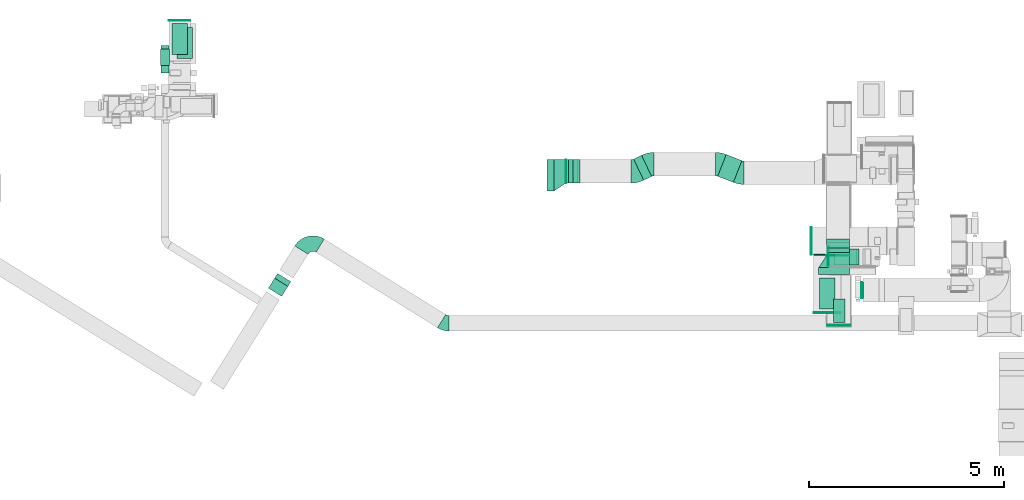
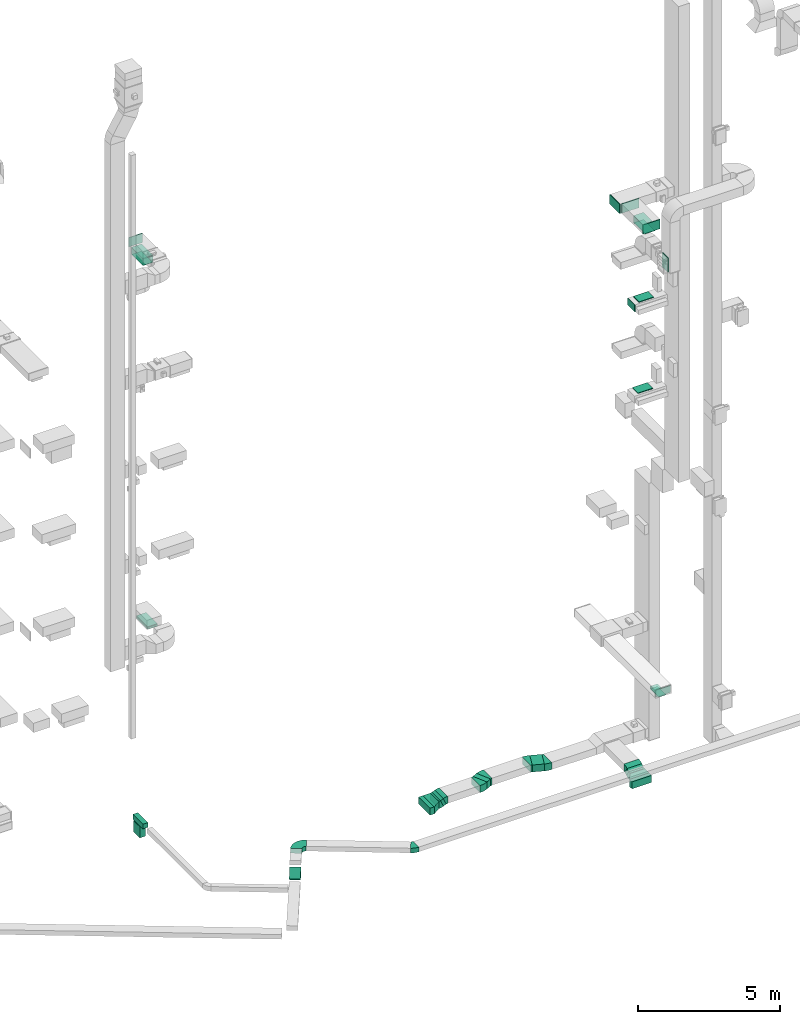
# One storey, part 11 of 25: 23 flow fittings, 18 flow segments, 3 flow terminals.
"""IFC2X3 building model written with IfcOpenShell, lengths in millimetres."""

from ifc_helpers import new_model, entity, si_unit, converted_unit, derived_unit, direction, frame, frame_2d, origin, origin_2d_with_axis, place, context, subcontext, project, spatial, polyline, circle_curve, parameter, trimmed, segment, composite_curve, rectangle, outline, extrude, source, transform, mapped, material, type_object, type_shapes, element, save


model = new_model("IFC2X3")

# Units and contexts
model_context = context("Model", 3, precision=0.01, world=origin(), true_north=direction((6.12303176911189e-17, 1.0)))
body_context = subcontext(model_context, "Body", "Model", "MODEL_VIEW")
ifc_project = project(units=[si_unit("LENGTHUNIT", "METRE", prefix="MILLI"), si_unit("AREAUNIT", "SQUARE_METRE"), si_unit("VOLUMEUNIT", "CUBIC_METRE"), converted_unit("PLANEANGLEUNIT", "DEGREE", entity("IfcRatioMeasure", 0.0174532925199433), si_unit("PLANEANGLEUNIT", "RADIAN"), dimensions=[0, 0, 0, 0, 0, 0, 0]), si_unit("MASSUNIT", "GRAM", prefix="KILO"), derived_unit("MASSDENSITYUNIT", [(si_unit("MASSUNIT", "GRAM", prefix="KILO"), 1), (si_unit("LENGTHUNIT", "METRE"), -3)]), derived_unit("MOMENTOFINERTIAUNIT", [(si_unit("LENGTHUNIT", "METRE"), 4)]), si_unit("TIMEUNIT", "SECOND"), si_unit("FREQUENCYUNIT", "HERTZ"), si_unit("THERMODYNAMICTEMPERATUREUNIT", "DEGREE_CELSIUS"), derived_unit("THERMALTRANSMITTANCEUNIT", [(si_unit("MASSUNIT", "GRAM", prefix="KILO"), 1), (si_unit("THERMODYNAMICTEMPERATUREUNIT", "KELVIN"), -1), (si_unit("TIMEUNIT", "SECOND"), -3)]), derived_unit("VOLUMETRICFLOWRATEUNIT", [(si_unit("LENGTHUNIT", "METRE"), 3), (si_unit("TIMEUNIT", "SECOND"), -1)]), derived_unit("MASSFLOWRATEUNIT", [(si_unit("MASSUNIT", "GRAM", prefix="KILO"), 1), (si_unit("TIMEUNIT", "SECOND"), -1)]), derived_unit("ROTATIONALFREQUENCYUNIT", [(si_unit("TIMEUNIT", "SECOND"), -1)]), si_unit("ELECTRICCURRENTUNIT", "AMPERE"), si_unit("ELECTRICVOLTAGEUNIT", "VOLT"), si_unit("POWERUNIT", "WATT"), si_unit("FORCEUNIT", "NEWTON", prefix="KILO"), si_unit("ILLUMINANCEUNIT", "LUX"), si_unit("LUMINOUSFLUXUNIT", "LUMEN"), si_unit("LUMINOUSINTENSITYUNIT", "CANDELA"), derived_unit("USERDEFINED", [(si_unit("MASSUNIT", "GRAM", prefix="KILO"), -1), (si_unit("LENGTHUNIT", "METRE"), -2), (si_unit("TIMEUNIT", "SECOND"), 3), (si_unit("LUMINOUSFLUXUNIT", "LUMEN"), 1)]), derived_unit("LINEARVELOCITYUNIT", [(si_unit("LENGTHUNIT", "METRE"), 1), (si_unit("TIMEUNIT", "SECOND"), -1)]), si_unit("PRESSUREUNIT", "PASCAL"), derived_unit("USERDEFINED", [(si_unit("LENGTHUNIT", "METRE"), -2), (si_unit("MASSUNIT", "GRAM", prefix="KILO"), 1), (si_unit("TIMEUNIT", "SECOND"), -2)]), derived_unit("LINEARFORCEUNIT", [(si_unit("MASSUNIT", "GRAM", prefix="KILO"), 1), (si_unit("LENGTHUNIT", "METRE"), 1), (si_unit("TIMEUNIT", "SECOND"), -2), (si_unit("LENGTHUNIT", "METRE"), -1)]), derived_unit("PLANARFORCEUNIT", [(si_unit("MASSUNIT", "GRAM", prefix="KILO"), 1), (si_unit("LENGTHUNIT", "METRE"), 1), (si_unit("TIMEUNIT", "SECOND"), -2), (si_unit("LENGTHUNIT", "METRE"), -2)])], contexts=[model_context])

# Site, building, storey
site_placement = place(None, origin())
site = spatial("IfcSite", under=ifc_project, at=site_placement, CompositionType="ELEMENT")
building_placement = place(site_placement, origin())
building = spatial("IfcBuilding", under=site, at=building_placement, CompositionType="ELEMENT")
storey_placement = place(building_placement, origin())
storey = spatial("IfcBuildingStorey", under=building, at=storey_placement, CompositionType="ELEMENT", Elevation=0.0)

# Flow segments
duct_segment_type = type_object("IfcDuctSegmentType", PredefinedType="NOTDEFINED")
flow_segment_1_placement = place(storey_placement, frame((28295.0, 9540.32, 22200.0)))
element("IfcFlowSegment", 1, at=flow_segment_1_placement, inside=storey, type_object=duct_segment_type, context=body_context, shape_type="SweptSolid", body=[
    extrude(rectangle(XDim=800.000000000001, YDim=400.0, at=origin_2d_with_axis()), frame((200.0, 400.0, 0.0), z_axis=(0.0, 0.0, 1.0), x_axis=(0.0, 1.0, 0.0)), (0.0, 0.0, 1.0), 280.000004231565),
])
flow_segment_2_placement = place(storey_placement, frame((28651.05, 9196.31, 2400.0)))
element("IfcFlowSegment", 2, at=flow_segment_2_placement, inside=storey, type_object=duct_segment_type, context=body_context, shape_type="SweptSolid", body=[
    extrude(rectangle(XDim=600.0, YDim=300.000000000001, at=origin_2d_with_axis()), frame((150.0, 300.0, 0.0), z_axis=(0.0, 0.0, 1.0), x_axis=(0.0, 1.0, 0.0)), (0.0, 0.0, 1.0), 79.9999999999699),
])
flow_segment_3_placement = place(storey_placement, frame((11808.22, 15969.97, 7100.0)))
element("IfcFlowSegment", 3, at=flow_segment_3_placement, inside=storey, type_object=duct_segment_type, context=body_context, shape_type="SweptSolid", body=[
    extrude(rectangle(XDim=800.0, YDim=400.0, at=origin_2d_with_axis()), frame((200.0, 400.0, 0.0), z_axis=(0.0, 0.0, 1.0), x_axis=(0.0, 1.0, 0.0)), (0.0, 0.0, 1.0), 79.9999999999991),
])
flow_segment_4_placement = place(storey_placement, frame((11399.83, 15599.98, -1100.0)))
element("IfcFlowSegment", 4, at=flow_segment_4_placement, inside=storey, type_object=duct_segment_type, context=body_context, shape_type="SweptSolid", body=[
    extrude(rectangle(XDim=705.699024463295, YDim=200.0, at=origin_2d_with_axis()), frame((100.0, 352.85, 0.0), z_axis=(0.0, 0.0, 1.0), x_axis=(0.0, 1.0, 0.0)), (0.0, 0.0, 1.0), 200.0),
])
flow_segment_5_placement = place(storey_placement, frame((11387.33, 15795.43, -1600.0)))
element("IfcFlowSegment", 5, at=flow_segment_5_placement, inside=storey, type_object=duct_segment_type, context=body_context, shape_type="SweptSolid", body=[
    extrude(rectangle(XDim=225.000000000001, YDim=425.000000000001, at=origin_2d_with_axis()), frame((112.5, 212.5, 0.0), z_axis=(0.0, 0.0, 1.0), x_axis=(-1.0, 0.0, 0.0)), (0.0, 0.0, 1.0), 479.999999999649),
])
flow_segment_6_placement = place(storey_placement, frame((28661.92, 10677.38, 14520.0)))
element("IfcFlowSegment", 6, at=flow_segment_6_placement, inside=storey, type_object=duct_segment_type, context=body_context, shape_type="SweptSolid", body=[
    extrude(rectangle(XDim=400.000000000002, YDim=600.000000000002, at=origin_2d_with_axis()), frame((300.0, 200.0, 0.0), z_axis=(0.0, 0.0, 1.0), x_axis=(0.0, 1.0, 0.0)), (0.0, 0.0, 1.0), 30.0000000000387),
])
flow_segment_7_placement = place(storey_placement, frame((14154.27, 9867.26, -997.49)))
element("IfcFlowSegment", 7, at=flow_segment_7_placement, inside=storey, type_object=duct_segment_type, context=body_context, shape_type="SweptSolid", body=[
    extrude(rectangle(XDim=199.999999999998, YDim=400.0, at=origin_2d_with_axis()), frame((207.08, 165.95, 70.71), z_axis=(0.374709505220615, 0.599660559564594, 0.707106781186548), x_axis=(-0.374709505220592, -0.599660559564608, 0.707106781186548)), (0.0, 0.0, 1.0), 429.289321881347),
])
flow_segment_8_placement = place(storey_placement, frame((28706.92, 10677.38, 18420.0)))
element("IfcFlowSegment", 8, at=flow_segment_8_placement, inside=storey, type_object=duct_segment_type, context=body_context, shape_type="SweptSolid", body=[
    extrude(rectangle(XDim=400.0, YDim=600.000000000002, at=origin_2d_with_axis()), frame((300.0, 200.0, 0.0), z_axis=(0.0, 0.0, 1.0), x_axis=(0.0, 1.0, 0.0)), (0.0, 0.0, 1.0), 30.0000000000148),
])
flow_segment_9_placement = place(storey_placement, frame((29370.56, 9824.93, 20000.0)))
element("IfcFlowSegment", 9, at=flow_segment_9_placement, inside=storey, type_object=duct_segment_type, context=body_context, shape_type="SweptSolid", body=[
    extrude(rectangle(XDim=24.9999999998774, YDim=400.0, at=origin_2d_with_axis()), frame((12.5, 200.0, 0.0), z_axis=(0.0, 0.0, 1.0), x_axis=(-1.0, 0.0, 0.0)), (0.0, 0.0, 1.0), 600.000000000002),
])
flow_segment_10_placement = place(storey_placement, frame((11675.64, 16071.13, 22700.0)))
element("IfcFlowSegment", 10, at=flow_segment_10_placement, inside=storey, type_object=duct_segment_type, context=body_context, shape_type="SweptSolid", body=[
    extrude(rectangle(XDim=400.0, YDim=800.0, at=origin_2d_with_axis()), frame((200.0, 400.0, 0.0)), (0.0, 0.0, 1.0), 280.00000000001),
])
flow_segment_11_placement = place(storey_placement, frame((21308.44, 12574.72, -2150.0)))
element("IfcFlowSegment", 11, at=flow_segment_11_placement, inside=storey, type_object=duct_segment_type, context=body_context, shape_type="SweptSolid", body=[
    extrude(rectangle(XDim=180.000000000167, YDim=800.0, at=origin_2d_with_axis()), frame((90.0, 400.0, 0.0)), (0.0, 0.0, 1.0), 300.0),
])
flow_segment_12_placement = place(storey_placement, frame((25682.11, 12791.58, -2050.0)))
element("IfcFlowSegment", 12, at=flow_segment_12_placement, inside=storey, type_object=duct_segment_type, context=body_context, shape_type="SweptSolid", body=[
    extrude(rectangle(XDim=431.766619119169, YDim=600.000000000001, at=origin_2d_with_axis()), frame((310.57, 358.14, 0.0), z_axis=(0.0, 0.0, 1.0), x_axis=(-0.930851591492938, 0.365397474834002, 0.0)), (0.0, 0.0, 1.0), 300.0),
])
flow_segment_13_placement = place(storey_placement, frame((23525.08, 12847.78, -2050.0)))
element("IfcFlowSegment", 13, at=flow_segment_13_placement, inside=storey, type_object=duct_segment_type, context=body_context, shape_type="SweptSolid", body=[
    extrude(rectangle(XDim=226.103922493207, YDim=600.0, at=origin_2d_with_axis()), frame((231.19, 319.45, 0.0), z_axis=(0.0, 0.0, 1.0), x_axis=(0.902595103311304, 0.430490510323348, 0.0)), (0.0, 0.0, 1.0), 300.0),
])
flow_segment_14_placement = place(storey_placement, frame((28269.95, 10425.0, -2150.0)))
element("IfcFlowSegment", 14, at=flow_segment_14_placement, inside=storey, type_object=duct_segment_type, context=body_context, shape_type="SweptSolid", body=[
    extrude(rectangle(XDim=180.000000000057, YDim=800.0, at=origin_2d_with_axis()), frame((400.0, 90.0, 0.0), z_axis=(0.0, 0.0, 1.0), x_axis=(0.0, -1.0, 0.0)), (0.0, 0.0, 1.0), 300.0),
])
flow_segment_15_placement = place(storey_placement, frame((28469.95, 10905.0, -2150.0)))
element("IfcFlowSegment", 15, at=flow_segment_15_placement, inside=storey, type_object=duct_segment_type, context=body_context, shape_type="SweptSolid", body=[
    extrude(rectangle(XDim=11.7313523662842, YDim=600.000000000002, at=origin_2d_with_axis()), frame((300.0, 5.87, 0.0), z_axis=(0.0, 0.0, 1.0), x_axis=(0.0, 1.0, 0.0)), (0.0, 0.0, 1.0), 300.0),
])
flow_segment_16_placement = place(storey_placement, frame((28469.95, 10991.73, -2089.71)))
element("IfcFlowSegment", 16, at=flow_segment_16_placement, inside=storey, type_object=duct_segment_type, context=body_context, shape_type="SweptSolid", body=[
    extrude(rectangle(XDim=299.999999999998, YDim=139.230496196381, at=frame_2d((0.0, 0.0), x_axis=(0.0, 1.0))), frame((0.0, 135.29, 164.71), z_axis=(1.0, 0.0, 0.0), x_axis=(0.0, 0.866025410712421, 0.499999988000383)), (0.0, 0.0, 1.0), 599.999999999998),
])
flow_segment_17_placement = place(storey_placement, frame((21788.44, 12774.72, -2150.0)))
element("IfcFlowSegment", 17, at=flow_segment_17_placement, inside=storey, type_object=duct_segment_type, context=body_context, shape_type="SweptSolid", body=[
    extrude(rectangle(XDim=6.88577027826406, YDim=600.0, at=origin_2d_with_axis()), frame((3.44, 300.0, 0.0)), (0.0, 0.0, 1.0), 300.0),
])
flow_segment_18_placement = place(storey_placement, frame((21855.76, 12774.72, -2111.85)))
element("IfcFlowSegment", 18, at=flow_segment_18_placement, inside=storey, type_object=duct_segment_type, context=body_context, shape_type="SweptSolid", body=[
    extrude(rectangle(XDim=300.000000000003, YDim=121.954891093288, at=frame_2d((0.0, 0.0), x_axis=(0.0, 1.0))), frame((116.25, 0.0, 161.85), z_axis=(0.0, 1.0, 0.0), x_axis=(-0.915231716678703, 0.0, -0.402927915122984)), (0.0, 0.0, 1.0), 600.000000000002),
])

# Flow fittings
ifc_material_1 = material()
duct_fitting_type_1 = type_object("IfcDuctFittingType", PredefinedType="NOTDEFINED", material=ifc_material_1)
shared_shape_1 = source(origin(), body_context, "Body", "SweptSolid", [
    extrude(rectangle(XDim=24.9999999999999, YDim=700.0, at=origin_2d_with_axis()), frame((12.5, 0.0, -200.0)), (0.0, 0.0, 1.0), 400.0),
])
type_shapes(duct_fitting_type_1, [shared_shape_1])
for number, where, z_axis, x_axis in (
    (19, (28495.0, 9460.01, 22500.0), (0.0, 0.0, 1.0), (0.0, -1.0, 0.0)),
    (20, (28095.0, 11289.62, 22500.0), (0.0, 0.0, 1.0), (-1.0, 0.0, 0.0)),
):
    element("IfcFlowFitting", number, at=place(storey_placement, frame(where, z_axis=z_axis, x_axis=x_axis)), inside=storey, type_object=duct_fitting_type_1, material=ifc_material_1, context=body_context, shape_type="MappedRepresentation", body=[
        mapped(shared_shape_1, transform((0.0, 0.0, 0.0), scale=1.0)),
    ])

# Flow terminal
ifc_material_2 = material()
air_terminal_type_1 = type_object("IfcAirTerminalType", PredefinedType="NOTDEFINED", material=ifc_material_2)
shared_shape_2 = source(origin(), body_context, "Body", "SweptSolid", [
    extrude(rectangle(XDim=4.0, YDim=799.999999999999, at=origin_2d_with_axis()), frame((0.0, -2.0, -200.0), z_axis=(0.0, 0.0, 1.0), x_axis=(0.0, 1.0, 0.0)), (0.0, 0.0, 1.0), 400.000000000005),
])
type_shapes(air_terminal_type_1, [shared_shape_2])
flow_terminal_1_placement = place(storey_placement, frame((28495.0, 9940.32, 22200.0), z_axis=(-1.0, 0.0, 0.0), x_axis=(0.0, -1.0, 0.0)))
element("IfcFlowTerminal", 21, at=flow_terminal_1_placement, inside=storey, type_object=air_terminal_type_1, material=ifc_material_2, context=body_context, shape_type="MappedRepresentation", body=[
    mapped(shared_shape_2, transform((0.0, 0.0, 0.0), scale=1.0)),
])

# Flow fittings
duct_fitting_type_2 = type_object("IfcDuctFittingType", PredefinedType="NOTDEFINED", material=ifc_material_1)
shared_shape_3 = source(origin(), body_context, "Body", "SweptSolid", [
    extrude(rectangle(XDim=26.0960000000012, YDim=800.0, at=origin_2d_with_axis()), frame((6.95, 0.0, -200.0)), (0.0, 0.0, 1.0), 400.0),
])
type_shapes(duct_fitting_type_2, [shared_shape_3])
flow_fitting_1_placement = place(storey_placement, frame((11875.64, 16471.13, 23000.0), z_axis=(1.0, 0.0, 0.0), x_axis=(0.0, 0.0, -1.0)))
element("IfcFlowFitting", 22, at=flow_fitting_1_placement, inside=storey, type_object=duct_fitting_type_2, material=ifc_material_1, context=body_context, shape_type="MappedRepresentation", body=[
    mapped(shared_shape_3, transform((0.0, 0.0, 0.0), scale=1.0)),
])
duct_fitting_type_3 = type_object("IfcDuctFittingType", PredefinedType="NOTDEFINED", material=ifc_material_1)
shared_shape_4 = source(origin(), body_context, "Body", "SweptSolid", [
    extrude(rectangle(XDim=800.0, YDim=26.096, at=origin_2d_with_axis()), frame((6.95, 0.0, -200.0), z_axis=(0.0, 0.0, 1.0), x_axis=(0.0, -1.0, 0.0)), (0.0, 0.0, 1.0), 400.0),
])
type_shapes(duct_fitting_type_3, [shared_shape_4])
flow_fitting_2_placement = place(storey_placement, frame((28495.0, 9940.32, 22500.0), z_axis=(-1.0, 0.0, 0.0), x_axis=(0.0, 0.0, -1.0)))
element("IfcFlowFitting", 23, at=flow_fitting_2_placement, inside=storey, type_object=duct_fitting_type_3, material=ifc_material_1, context=body_context, shape_type="MappedRepresentation", body=[
    mapped(shared_shape_4, transform((0.0, 0.0, 0.0), scale=1.0)),
])
duct_fitting_type_4 = type_object("IfcDuctFittingType", PredefinedType="NOTDEFINED", material=ifc_material_1)
shared_shape_5 = source(origin(), body_context, "Body", "SweptSolid", [
    extrude(rectangle(XDim=400.0, YDim=26.0960000000022, at=origin_2d_with_axis()), frame((6.95, 0.0, -400.0), z_axis=(0.0, 0.0, 1.0), x_axis=(0.0, -1.0, 0.0)), (0.0, 0.0, 1.0), 800.0),
])
type_shapes(duct_fitting_type_4, [shared_shape_5])
flow_fitting_3_placement = place(storey_placement, frame((12008.22, 16369.97, 7200.0), z_axis=(0.0, 1.0, 0.0), x_axis=(0.0, 0.0, -1.0)))
element("IfcFlowFitting", 24, at=flow_fitting_3_placement, inside=storey, type_object=duct_fitting_type_4, material=ifc_material_1, context=body_context, shape_type="MappedRepresentation", body=[
    mapped(shared_shape_5, transform((0.0, 0.0, 0.0), scale=1.0)),
])
duct_fitting_type_5 = type_object("IfcDuctFittingType", PredefinedType="NOTDEFINED", material=ifc_material_1)
shared_shape_6 = source(origin(), body_context, "Body", "SweptSolid", [
    extrude(rectangle(XDim=24.9999999999999, YDim=600.0, at=origin_2d_with_axis()), frame((12.5, 0.0, -150.0)), (0.0, 0.0, 1.0), 300.0),
])
type_shapes(duct_fitting_type_5, [shared_shape_6])
flow_fitting_4_placement = place(storey_placement, frame((28789.1, 9142.08, 2650.0), z_axis=(0.0, 0.0, 1.0), x_axis=(0.0, -1.0, 0.0)))
element("IfcFlowFitting", 25, at=flow_fitting_4_placement, inside=storey, type_object=duct_fitting_type_5, material=ifc_material_1, context=body_context, shape_type="MappedRepresentation", body=[
    mapped(shared_shape_6, transform((0.0, 0.0, 0.0), scale=1.0)),
])
duct_fitting_type_6 = type_object("IfcDuctFittingType", PredefinedType="NOTDEFINED", material=ifc_material_1)
shared_shape_7 = source(origin(), body_context, "Body", "SweptSolid", [
    extrude(rectangle(XDim=300.0, YDim=26.0960000000498, at=origin_2d_with_axis()), frame((6.95, 0.0, -300.0), z_axis=(0.0, 0.0, 1.0), x_axis=(0.0, -1.0, 0.0)), (0.0, 0.0, 1.0), 600.0),
])
type_shapes(duct_fitting_type_6, [shared_shape_7])
flow_fitting_5_placement = place(storey_placement, frame((28801.05, 9496.31, 2500.0), z_axis=(0.0, 1.0, 0.0), x_axis=(0.0, 0.0, -1.0)))
element("IfcFlowFitting", 26, at=flow_fitting_5_placement, inside=storey, type_object=duct_fitting_type_6, material=ifc_material_1, context=body_context, shape_type="MappedRepresentation", body=[
    mapped(shared_shape_7, transform((0.0, 0.0, 0.0), scale=1.0)),
])

# Flow terminal
air_terminal_type_2 = type_object("IfcAirTerminalType", PredefinedType="NOTDEFINED", material=ifc_material_2)
shared_shape_8 = source(origin(), body_context, "Body", "SweptSolid", [
    extrude(rectangle(XDim=4.0, YDim=599.999999999999, at=origin_2d_with_axis()), frame((0.0, -2.0, -150.0), z_axis=(0.0, 0.0, 1.0), x_axis=(0.0, 1.0, 0.0)), (0.0, 0.0, 1.0), 300.000000000005),
])
type_shapes(air_terminal_type_2, [shared_shape_8])
flow_terminal_2_placement = place(storey_placement, frame((28801.05, 9496.31, 2400.0), z_axis=(-1.0, 0.0, 0.0), x_axis=(0.0, -1.0, 0.0)))
element("IfcFlowTerminal", 27, at=flow_terminal_2_placement, inside=storey, type_object=air_terminal_type_2, material=ifc_material_2, context=body_context, shape_type="MappedRepresentation", body=[
    mapped(shared_shape_8, transform((0.0, 0.0, 0.0), scale=1.0)),
])

# Flow fittings
duct_fitting_type_7 = type_object("IfcDuctFittingType", PredefinedType="NOTDEFINED", material=ifc_material_1)
shared_shape_9 = source(origin(), body_context, "Body", "SweptSolid", [
    extrude(rectangle(XDim=24.9999999999999, YDim=500.0, at=origin_2d_with_axis()), frame((12.5, 0.0, -150.0)), (0.0, 0.0, 1.0), 300.0),
])
type_shapes(duct_fitting_type_7, [shared_shape_9])
flow_fitting_6_placement = place(storey_placement, frame((28533.94, 10897.38, 18250.0), z_axis=(0.0, 0.0, 1.0), x_axis=(-1.0, 0.0, 0.0)))
element("IfcFlowFitting", 28, at=flow_fitting_6_placement, inside=storey, type_object=duct_fitting_type_7, material=ifc_material_1, context=body_context, shape_type="MappedRepresentation", body=[
    mapped(shared_shape_9, transform((0.0, 0.0, 0.0), scale=1.0)),
])
duct_fitting_type_8 = type_object("IfcDuctFittingType", PredefinedType="NOTDEFINED", material=ifc_material_1)
shared_shape_10 = source(origin(), body_context, "Body", "SweptSolid", [
    extrude(rectangle(XDim=24.9999999999999, YDim=550.0, at=origin_2d_with_axis()), frame((12.5, 0.0, -200.0)), (0.0, 0.0, 1.0), 400.0),
])
type_shapes(duct_fitting_type_8, [shared_shape_10])
flow_fitting_7_placement = place(storey_placement, frame((11874.64, 16933.77, 23200.0), z_axis=(0.0, 0.0, 1.0), x_axis=(0.0, 1.0, 0.0)))
element("IfcFlowFitting", 29, at=flow_fitting_7_placement, inside=storey, type_object=duct_fitting_type_8, material=ifc_material_1, context=body_context, shape_type="MappedRepresentation", body=[
    mapped(shared_shape_10, transform((0.0, 0.0, 0.0), scale=1.0)),
])
duct_fitting_type_9 = type_object("IfcDuctFittingType", PredefinedType="NOTDEFINED", material=ifc_material_1)
shared_shape_11 = source(origin(), body_context, "Body", "SweptSolid", [
    extrude(rectangle(XDim=600.0, YDim=26.096, at=origin_2d_with_axis()), frame((6.95, 0.0, -200.0), z_axis=(0.0, 0.0, 1.0), x_axis=(0.0, -1.0, 0.0)), (0.0, 0.0, 1.0), 400.0),
])
type_shapes(duct_fitting_type_9, [shared_shape_11])
flow_fitting_8_placement = place(storey_placement, frame((29415.56, 10024.93, 20300.0), z_axis=(0.0, 1.0, 0.0), x_axis=(-1.0, 0.0, 0.0)))
element("IfcFlowFitting", 30, at=flow_fitting_8_placement, inside=storey, type_object=duct_fitting_type_9, material=ifc_material_1, context=body_context, shape_type="MappedRepresentation", body=[
    mapped(shared_shape_11, transform((0.0, 0.0, 0.0), scale=1.0)),
])

# Flow terminal
air_terminal_type_3 = type_object("IfcAirTerminalType", PredefinedType="NOTDEFINED", material=ifc_material_2)
shared_shape_12 = source(origin(), body_context, "Body", "SweptSolid", [
    extrude(rectangle(XDim=4.0, YDim=799.999999999999, at=origin_2d_with_axis()), frame((0.0, -2.0, -200.0), z_axis=(0.0, 0.0, 1.0), x_axis=(0.0, 1.0, 0.0)), (0.0, 0.0, 1.0), 400.000000000005),
])
type_shapes(air_terminal_type_3, [shared_shape_12])
flow_terminal_3_placement = place(storey_placement, frame((11875.64, 16470.13, 22700.0), z_axis=(-1.0, 0.0, 0.0), x_axis=(0.0, -1.0, 0.0)))
element("IfcFlowTerminal", 31, at=flow_terminal_3_placement, inside=storey, type_object=air_terminal_type_3, material=ifc_material_2, context=body_context, shape_type="MappedRepresentation", body=[
    mapped(shared_shape_12, transform((0.0, 0.0, 0.0), scale=1.0)),
])

# Flow fittings
duct_fitting_type_10 = type_object("IfcDuctFittingType", PredefinedType="NOTDEFINED", material=ifc_material_1)
shared_shape_13 = source(origin(), body_context, "Body", "SweptSolid", [
    extrude(rectangle(XDim=700.0, YDim=26.096, at=origin_2d_with_axis()), frame((6.95, 0.0, -200.0), z_axis=(0.0, 0.0, 1.0), x_axis=(0.0, -1.0, 0.0)), (0.0, 0.0, 1.0), 400.0),
])
type_shapes(duct_fitting_type_10, [shared_shape_13])
flow_fitting_9_placement = place(storey_placement, frame((28495.0, 10939.62, 22500.0), z_axis=(0.0, 0.0, -1.0), x_axis=(0.0, -1.0, 0.0)))
element("IfcFlowFitting", 32, at=flow_fitting_9_placement, inside=storey, type_object=duct_fitting_type_10, material=ifc_material_1, context=body_context, shape_type="MappedRepresentation", body=[
    mapped(shared_shape_13, transform((0.0, 0.0, 0.0), scale=1.0)),
])
duct_fitting_type_11 = type_object("IfcDuctFittingType", PredefinedType="NOTDEFINED", material=ifc_material_1)
shared_shape_14 = source(origin(), body_context, "Body", "SweptSolid", [
    extrude(outline(polyline([(-374.42, -291.22), (-13.87, -291.22), (318.95, 208.01), (69.34, 374.42), (-374.42, -291.22)])), frame((150.0, 50.0, -150.0), z_axis=(0.0, 0.0, 1.0), x_axis=(0.832050294337843, 0.55470019622523, 0.0)), (0.0, 0.0, 1.0), 300.0),
])
type_shapes(duct_fitting_type_11, [shared_shape_14])
flow_fitting_10_placement = place(storey_placement, frame((21488.44, 12974.72, -2000.0)))
element("IfcFlowFitting", 33, at=flow_fitting_10_placement, inside=storey, type_object=duct_fitting_type_11, material=ifc_material_1, context=body_context, shape_type="MappedRepresentation", body=[
    mapped(shared_shape_14, transform((0.0, 0.0, 0.0), scale=1.0)),
])
duct_fitting_type_12 = type_object("IfcDuctFittingType", PredefinedType="NOTDEFINED", material=ifc_material_1)
shared_shape_15 = source(origin(), body_context, "Body", "SweptSolid", [
    extrude(outline(polyline([(-150.0, -350.0), (150.0, -350.0), (150.0, 250.0), (-150.0, 450.0), (-150.0, -350.0)])), frame((150.0, -50.0, -150.0)), (0.0, 0.0, 1.0), 300.0),
])
type_shapes(duct_fitting_type_12, [shared_shape_15])
flow_fitting_11_placement = place(storey_placement, frame((28669.95, 10605.0, -2000.0), z_axis=(0.0, 0.0, 1.0), x_axis=(0.0, 1.0, 0.0)))
element("IfcFlowFitting", 34, at=flow_fitting_11_placement, inside=storey, type_object=duct_fitting_type_12, material=ifc_material_1, context=body_context, shape_type="MappedRepresentation", body=[
    mapped(shared_shape_15, transform((0.0, 0.0, 0.0), scale=1.0)),
])
duct_fitting_type_13 = type_object("IfcDuctFittingType", PredefinedType="NOTDEFINED", material=ifc_material_1)
shared_shape_16 = source(origin(), body_context, "Body", "SweptSolid", [
    extrude(outline(composite_curve([segment(polyline([(-315.56, -82.21), (284.44, -82.21)]), True, "CONTINUOUS"), segment(trimmed(circle_curve(frame_2d((434.44, -82.21), x_axis=(-0.930851591492948, 0.365397474833975)), 150.0), [parameter(0.0)], [parameter(21.4320460265405)], True, "PARAMETER"), False, "CONTINUOUS"), segment(polyline([(294.81, -27.4), (-263.7, 191.83)]), True, "CONTINUOUS"), segment(trimmed(circle_curve(frame_2d((434.44, -82.21), x_axis=(-0.930851591492948, 0.365397474833975)), 750.0), [parameter(0.0)], [parameter(21.4320460265405)], True, "PARAMETER"), True, "CONTINUOUS")], self_intersect=False)), frame((-2.94, 15.56, -150.0), z_axis=(0.0, 0.0, 1.0), x_axis=(-0.365397474833975, 0.930851591492948, 0.0)), (0.0, 0.0, 1.0), 300.0),
])
type_shapes(duct_fitting_type_13, [shared_shape_16])
for number, where, z_axis, x_axis in (
    (35, (25712.46, 13259.72, -1900.0), (0.0, 0.0, 1.0), (-0.930851591492938, 0.365397474834001, 0.0)),
    (36, (26272.91, 13039.72, -1900.0), (0.0, 0.0, 1.0), (0.930851591492938, -0.365397474834, 0.0)),
):
    element("IfcFlowFitting", number, at=place(storey_placement, frame(where, z_axis=z_axis, x_axis=x_axis)), inside=storey, type_object=duct_fitting_type_13, material=ifc_material_1, context=body_context, shape_type="MappedRepresentation", body=[
        mapped(shared_shape_16, transform((0.0, 0.0, 0.0), scale=1.0)),
    ])
duct_fitting_type_14 = type_object("IfcDuctFittingType", PredefinedType="NOTDEFINED", material=ifc_material_1)
shared_shape_17 = source(origin(), body_context, "Body", "SweptSolid", [
    extrude(outline(composite_curve([segment(polyline([(-321.92, -96.86), (278.08, -96.86)]), True, "CONTINUOUS"), segment(trimmed(circle_curve(frame_2d((428.08, -96.86), x_axis=(-0.902595103311302, 0.430490510323354)), 150.0), [parameter(0.0)], [parameter(25.4986931846699)], True, "PARAMETER"), False, "CONTINUOUS"), segment(polyline([(292.69, -32.29), (-248.86, 226.01)]), True, "CONTINUOUS"), segment(trimmed(circle_curve(frame_2d((428.08, -96.86), x_axis=(-0.902595103311302, 0.430490510323354)), 750.0), [parameter(0.0)], [parameter(25.4986931846699)], True, "PARAMETER"), True, "CONTINUOUS")], self_intersect=False)), frame((-4.96, 21.92, -150.0), z_axis=(0.0, 0.0, 1.0), x_axis=(-0.430490510323354, 0.902595103311301, 0.0)), (0.0, 0.0, 1.0), 300.0),
])
type_shapes(duct_fitting_type_14, [shared_shape_17])
flow_fitting_12_placement = place(storey_placement, frame((23950.21, 13259.72, -1900.0), z_axis=(0.0, 0.0, 1.0), x_axis=(-1.0, 0.0, 0.0)))
element("IfcFlowFitting", 37, at=flow_fitting_12_placement, inside=storey, type_object=duct_fitting_type_14, material=ifc_material_1, context=body_context, shape_type="MappedRepresentation", body=[
    mapped(shared_shape_17, transform((0.0, 0.0, 0.0), scale=1.0)),
])
flow_fitting_13_placement = place(storey_placement, frame((23562.33, 13074.72, -1900.0)))
element("IfcFlowFitting", 38, at=flow_fitting_13_placement, inside=storey, type_object=duct_fitting_type_14, material=ifc_material_1, context=body_context, shape_type="MappedRepresentation", body=[
    mapped(shared_shape_17, transform((0.0, 0.0, 0.0), scale=1.0)),
])
duct_fitting_type_15 = type_object("IfcDuctFittingType", PredefinedType="NOTDEFINED", material=ifc_material_1)
shared_shape_18 = source(origin(), body_context, "Body", "SweptSolid", [
    extrude(outline(composite_curve([segment(polyline([(-170.1, -75.0), (129.9, -75.0)]), True, "CONTINUOUS"), segment(trimmed(circle_curve(frame_2d((279.9, -75.0), x_axis=(-0.866025410712478, 0.499999988000285)), 150.0), [parameter(0.0)], [parameter(29.9999992061053)], True, "PARAMETER"), False, "CONTINUOUS"), segment(polyline([(150.0, 0.0), (-109.81, 150.0)]), True, "CONTINUOUS"), segment(trimmed(circle_curve(frame_2d((279.9, -75.0), x_axis=(-0.866025410712478, 0.499999988000285)), 450.0), [parameter(0.0)], [parameter(29.9999992061053)], True, "PARAMETER"), True, "CONTINUOUS")], self_intersect=False)), frame((-5.38, 20.1, -300.0), z_axis=(0.0, 0.0, 1.0), x_axis=(-0.499999988000285, 0.866025410712477, 0.0)), (0.0, 0.0, 1.0), 600.0),
])
type_shapes(duct_fitting_type_15, [shared_shape_18])
for number, where, z_axis, x_axis in (
    (39, (28769.95, 10997.12, -2000.0), (1.0, 0.0, 0.0), (0.0, 1.0, 0.0)),
    (40, (28769.95, 11256.92, -1850.0), (-1.0, 0.0, 0.0), (0.0, 0.866025410712447, 0.499999988000337)),
):
    element("IfcFlowFitting", number, at=place(storey_placement, frame(where, z_axis=z_axis, x_axis=x_axis)), inside=storey, type_object=duct_fitting_type_15, material=ifc_material_1, context=body_context, shape_type="MappedRepresentation", body=[
        mapped(shared_shape_18, transform((0.0, 0.0, 0.0), scale=1.0)),
    ])
duct_fitting_type_16 = type_object("IfcDuctFittingType", PredefinedType="NOTDEFINED", material=ifc_material_1)
shared_shape_19 = source(origin(), body_context, "Body", "SweptSolid", [
    extrude(outline(composite_curve([segment(polyline([(-162.72, -60.44), (137.28, -60.44)]), True, "CONTINUOUS"), segment(trimmed(circle_curve(frame_2d((287.28, -60.44), x_axis=(-0.915231716678761, 0.402927915122853)), 150.0), [parameter(0.0)], [parameter(23.7613446574382)], True, "PARAMETER"), False, "CONTINUOUS"), segment(polyline([(150.0, 0.0), (-124.57, 120.88)]), True, "CONTINUOUS"), segment(trimmed(circle_curve(frame_2d((287.28, -60.44), x_axis=(-0.915231716678761, 0.402927915122853)), 450.0), [parameter(0.0)], [parameter(23.7613446574382)], True, "PARAMETER"), True, "CONTINUOUS")], self_intersect=False)), frame((-2.68, 12.72, -300.0), z_axis=(0.0, 0.0, 1.0), x_axis=(-0.402927915122853, 0.915231716678761, 0.0)), (0.0, 0.0, 1.0), 600.0),
])
type_shapes(duct_fitting_type_16, [shared_shape_19])
for number, where, z_axis, x_axis in (
    (41, (22085.58, 13074.72, -1900.0), (0.0, -1.0, 0.0), (-1.0, 0.0, 0.0)),
    (42, (21858.44, 13074.72, -2000.0), (0.0, -1.0, 0.0), (1.0, 0.0, 0.0)),
):
    element("IfcFlowFitting", number, at=place(storey_placement, frame(where, z_axis=z_axis, x_axis=x_axis)), inside=storey, type_object=duct_fitting_type_16, material=ifc_material_1, context=body_context, shape_type="MappedRepresentation", body=[
        mapped(shared_shape_19, transform((0.0, 0.0, 0.0), scale=1.0)),
    ])
duct_fitting_type_17 = type_object("IfcDuctFittingType", PredefinedType="NOTDEFINED", material=ifc_material_1)
shared_shape_20 = source(origin(), body_context, "Body", "SweptSolid", [
    extrude(outline(composite_curve([segment(polyline([(-226.33, -92.32), (173.67, -92.32)]), True, "CONTINUOUS"), segment(trimmed(circle_curve(frame_2d((323.67, -92.32), x_axis=(-0.849526449943788, 0.527546027229758)), 150.0), [parameter(0.0)], [parameter(31.8397992290732)], True, "PARAMETER"), False, "CONTINUOUS"), segment(polyline([(196.24, -13.19), (-143.57, 197.83)]), True, "CONTINUOUS"), segment(trimmed(circle_curve(frame_2d((323.67, -92.32), x_axis=(-0.849526449943788, 0.527546027229758)), 550.0), [parameter(0.0)], [parameter(31.8397992290732)], True, "PARAMETER"), True, "CONTINUOUS")], self_intersect=False)), frame((-7.51, 26.33, -100.0), z_axis=(0.0, 0.0, 1.0), x_axis=(-0.527546027229759, 0.84952644994379, 0.0)), (0.0, 0.0, 1.0), 200.0),
])
type_shapes(duct_fitting_type_17, [shared_shape_20])
flow_fitting_14_placement = place(storey_placement, frame((18683.44, 9180.0, -550.0), z_axis=(0.0, 0.0, 1.0), x_axis=(0.84952644994379, -0.527546027229759, 0.0)))
element("IfcFlowFitting", 43, at=flow_fitting_14_placement, inside=storey, type_object=duct_fitting_type_17, material=ifc_material_1, context=body_context, shape_type="MappedRepresentation", body=[
    mapped(shared_shape_20, transform((0.0, 0.0, 0.0), scale=1.0)),
])
duct_fitting_type_18 = type_object("IfcDuctFittingType", PredefinedType="NOTDEFINED", material=ifc_material_1)
shared_shape_21 = source(origin(), body_context, "Body", "SweptSolid", [
    extrude(outline(composite_curve([segment(polyline([(-374.51, -175.0), (25.49, -175.0)]), True, "CONTINUOUS"), segment(trimmed(circle_curve(frame_2d((175.49, -175.0), x_axis=(-0.00279602727377437, 0.999996091108102)), 150.0), [parameter(0.0)], [parameter(89.8397992290734)], True, "PARAMETER"), False, "CONTINUOUS"), segment(polyline([(175.07, -25.0), (173.95, 375.0)]), True, "CONTINUOUS"), segment(trimmed(circle_curve(frame_2d((175.49, -175.0), x_axis=(-0.00279602727377437, 0.999996091108102)), 550.0), [parameter(0.0)], [parameter(89.8397992290733)], True, "PARAMETER"), True, "CONTINUOUS")], self_intersect=False)), frame((-174.02, 174.51, -100.0), z_axis=(0.0, 0.0, 1.0), x_axis=(-0.999996091108103, 0.00279602727377631, 0.0)), (0.0, 0.0, 1.0), 200.0),
])
type_shapes(duct_fitting_type_18, [shared_shape_21])
flow_fitting_15_placement = place(storey_placement, frame((15185.53, 11352.16, -550.0), z_axis=(0.0, 0.0, 1.0), x_axis=(-0.849526449943789, 0.527546027229761, 0.0)))
element("IfcFlowFitting", 44, at=flow_fitting_15_placement, inside=storey, type_object=duct_fitting_type_18, material=ifc_material_1, context=body_context, shape_type="MappedRepresentation", body=[
    mapped(shared_shape_21, transform((0.0, 0.0, 0.0), scale=1.0)),
])

save(model, "model.ifc")
